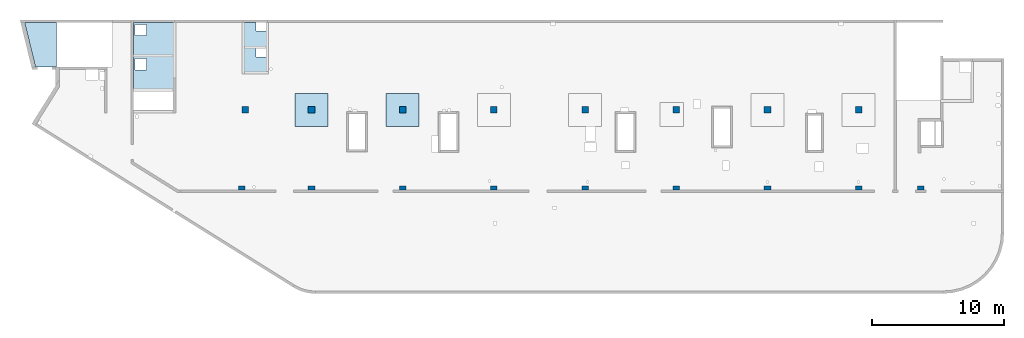
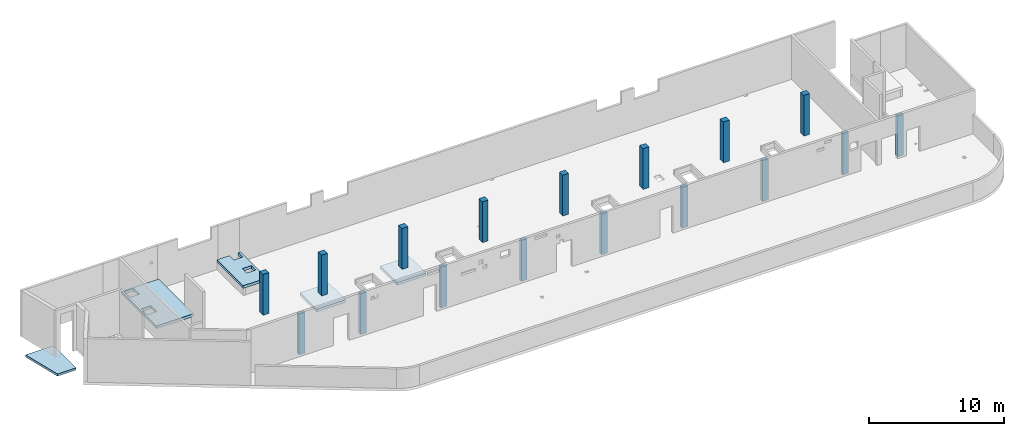
# One storey, part 1 of 6: 17 columns, 5 slabs.
"""IFC4 building model written with IfcOpenShell, lengths in millimetres."""

from ifc_helpers import new_model, entity, si_unit, converted_unit, derived_unit, direction, frame, origin, place, context, subcontext, project, spatial, indexed_curve, outline, extrude, source, transform, mapped, material, type_object, type_shapes, element, save


model = new_model("IFC4")

# Units and contexts
model_context = context("Model", 3, precision=0.01, world=origin(), true_north=direction((6.12303176911189e-17, 1.0)))
plan_context = context("Plan", 3, precision=0.01, world=origin(), true_north=direction((6.12303176911189e-17, 1.0)))
body_context = subcontext(model_context, "Body", "Model", "MODEL_VIEW")
ifc_project = project(units=[si_unit("LENGTHUNIT", "METRE", prefix="MILLI"), si_unit("AREAUNIT", "SQUARE_METRE"), si_unit("VOLUMEUNIT", "CUBIC_METRE"), converted_unit("PLANEANGLEUNIT", "DEGREE", entity("IfcRatioMeasure", 0.0174532925199433), si_unit("PLANEANGLEUNIT", "RADIAN"), dimensions=[0, 0, 0, 0, 0, 0, 0]), si_unit("MASSUNIT", "GRAM", prefix="KILO"), derived_unit("MASSDENSITYUNIT", [(si_unit("MASSUNIT", "GRAM", prefix="KILO"), 1), (si_unit("LENGTHUNIT", "METRE"), -3)]), derived_unit("MOMENTOFINERTIAUNIT", [(si_unit("LENGTHUNIT", "METRE"), 4)]), si_unit("TIMEUNIT", "SECOND"), si_unit("FREQUENCYUNIT", "HERTZ"), si_unit("THERMODYNAMICTEMPERATUREUNIT", "DEGREE_CELSIUS"), derived_unit("THERMALTRANSMITTANCEUNIT", [(si_unit("MASSUNIT", "GRAM", prefix="KILO"), 1), (si_unit("THERMODYNAMICTEMPERATUREUNIT", "KELVIN"), -1), (si_unit("TIMEUNIT", "SECOND"), -3)]), derived_unit("VOLUMETRICFLOWRATEUNIT", [(si_unit("LENGTHUNIT", "METRE"), 3), (si_unit("TIMEUNIT", "SECOND"), -1)]), derived_unit("MASSFLOWRATEUNIT", [(si_unit("MASSUNIT", "GRAM", prefix="KILO"), 1), (si_unit("TIMEUNIT", "SECOND"), -1)]), derived_unit("ROTATIONALFREQUENCYUNIT", [(si_unit("TIMEUNIT", "SECOND"), -1)]), si_unit("ELECTRICCURRENTUNIT", "AMPERE"), si_unit("ELECTRICVOLTAGEUNIT", "VOLT"), si_unit("POWERUNIT", "WATT"), si_unit("FORCEUNIT", "NEWTON", prefix="KILO"), si_unit("ILLUMINANCEUNIT", "LUX"), si_unit("LUMINOUSFLUXUNIT", "LUMEN"), si_unit("LUMINOUSINTENSITYUNIT", "CANDELA"), derived_unit("USERDEFINED", [(si_unit("MASSUNIT", "GRAM", prefix="KILO"), -1), (si_unit("LENGTHUNIT", "METRE"), -2), (si_unit("TIMEUNIT", "SECOND"), 3), (si_unit("LUMINOUSFLUXUNIT", "LUMEN"), 1)]), derived_unit("LINEARVELOCITYUNIT", [(si_unit("LENGTHUNIT", "METRE"), 1), (si_unit("TIMEUNIT", "SECOND"), -1)]), si_unit("PRESSUREUNIT", "PASCAL"), derived_unit("USERDEFINED", [(si_unit("LENGTHUNIT", "METRE"), -2), (si_unit("MASSUNIT", "GRAM", prefix="KILO"), 1), (si_unit("TIMEUNIT", "SECOND"), -2)]), derived_unit("LINEARFORCEUNIT", [(si_unit("MASSUNIT", "GRAM", prefix="KILO"), 1), (si_unit("LENGTHUNIT", "METRE"), 1), (si_unit("TIMEUNIT", "SECOND"), -2), (si_unit("LENGTHUNIT", "METRE"), -1)]), derived_unit("PLANARFORCEUNIT", [(si_unit("MASSUNIT", "GRAM", prefix="KILO"), 1), (si_unit("LENGTHUNIT", "METRE"), 1), (si_unit("TIMEUNIT", "SECOND"), -2), (si_unit("LENGTHUNIT", "METRE"), -2)])], contexts=[model_context, plan_context])

# Site, building, storey
site_placement = place(None, origin())
site = spatial("IfcSite", under=ifc_project, at=site_placement, CompositionType="ELEMENT")
building_placement = place(site_placement, origin())
building = spatial("IfcBuilding", under=site, at=building_placement, CompositionType="ELEMENT")
storey_placement = place(building_placement, frame((0.0, 0.0, 28200.0)))
storey = spatial("IfcBuildingStorey", under=building, at=storey_placement, CompositionType="ELEMENT", Elevation=28200.0)

# Columns
ifc_material = material()
column_type_1 = type_object("IfcColumnType", PredefinedType="COLUMN", material=ifc_material)
shared_shape_1 = source(origin(), body_context, "Body", "SweptSolid", [
    extrude(outline(indexed_curve([(-149.999999999996, -249.999999999999), (149.999999999995, -249.999999999999), (149.999999999997, 249.999999999999), (-149.999999999997, 249.999999999999), (-149.999999999996, -249.999999999999)], self_intersect=False)), frame((15899.9995239258, 7799.99922635584, 28050.0), z_axis=(0.0, 0.0, 1.0), x_axis=(0.0, -1.0, 0.0)), (0.0, 0.0, 1.0), 3700.0),
])
type_shapes(column_type_1, [shared_shape_1])
column_1_placement = place(storey_placement, frame((0.0, 0.0, -28200.0)))
element("IfcColumn", 1, at=column_1_placement, inside=storey, type_object=column_type_1, PredefinedType="COLUMN", context=body_context, shape_type="MappedRepresentation", body=[
    mapped(shared_shape_1, transform((0.0, 0.0, 0.0), scale=1.0)),
])
column_type_2 = type_object("IfcColumnType", PredefinedType="COLUMN", material=ifc_material)
shared_shape_2 = source(origin(), body_context, "Body", "SweptSolid", [
    extrude(outline(indexed_curve([(-149.999999999996, -249.999999999999), (149.999999999995, -249.999999999999), (149.999999999996, 249.999999999999), (-149.999999999997, 249.999999999999), (-149.999999999996, -249.999999999999)], self_intersect=False)), frame((21170.0002685547, 7799.99922635582, 28050.0), z_axis=(0.0, 0.0, 1.0), x_axis=(0.0, -1.0, 0.0)), (0.0, 0.0, 1.0), 3700.0),
])
type_shapes(column_type_2, [shared_shape_2])
column_2_placement = place(storey_placement, frame((0.0, 0.0, -28200.0)))
element("IfcColumn", 2, at=column_2_placement, inside=storey, type_object=column_type_2, PredefinedType="COLUMN", context=body_context, shape_type="MappedRepresentation", body=[
    mapped(shared_shape_2, transform((0.0, 0.0, 0.0), scale=1.0)),
])
column_type_3 = type_object("IfcColumnType", PredefinedType="COLUMN", material=ifc_material)
shared_shape_3 = source(origin(), body_context, "Body", "SweptSolid", [
    extrude(outline(indexed_curve([(-149.999999999996, -249.999999999999), (149.999999999995, -249.999999999999), (149.999999999996, 249.999999999999), (-149.999999999996, 249.999999999999), (-149.999999999996, -249.999999999999)], self_intersect=False)), frame((28070.0002685547, 7799.9992263558, 28050.0), z_axis=(0.0, 0.0, 1.0), x_axis=(0.0, -1.0, 0.0)), (0.0, 0.0, 1.0), 3700.0),
])
type_shapes(column_type_3, [shared_shape_3])
column_3_placement = place(storey_placement, frame((0.0, 0.0, -28200.0)))
element("IfcColumn", 3, at=column_3_placement, inside=storey, type_object=column_type_3, PredefinedType="COLUMN", context=body_context, shape_type="MappedRepresentation", body=[
    mapped(shared_shape_3, transform((0.0, 0.0, 0.0), scale=1.0)),
])
column_type_4 = type_object("IfcColumnType", PredefinedType="COLUMN", material=ifc_material)
shared_shape_4 = source(origin(), body_context, "Body", "SweptSolid", [
    extrude(outline(indexed_curve([(-149.999999999994, -249.999999999999), (149.999999999995, -249.999999999999), (149.999999999996, 249.999999999995), (-149.999999999995, 249.999999999999), (-149.999999999994, -249.999999999999)], self_intersect=False)), frame((34970.0002685547, 7799.99922635578, 28050.0), z_axis=(0.0, 0.0, 1.0), x_axis=(0.0, -1.0, 0.0)), (0.0, 0.0, 1.0), 3700.0),
])
type_shapes(column_type_4, [shared_shape_4])
column_4_placement = place(storey_placement, frame((0.0, 0.0, -28200.0)))
element("IfcColumn", 4, at=column_4_placement, inside=storey, type_object=column_type_4, PredefinedType="COLUMN", context=body_context, shape_type="MappedRepresentation", body=[
    mapped(shared_shape_4, transform((0.0, 0.0, 0.0), scale=1.0)),
])
column_type_5 = type_object("IfcColumnType", PredefinedType="COLUMN", material=ifc_material)
shared_shape_5 = source(origin(), body_context, "Body", "SweptSolid", [
    extrude(outline(indexed_curve([(-149.999999999994, -250.000000000004), (149.999999999995, -250.000000000004), (149.999999999996, 250.000000000004), (-149.999999999994, 250.000000000004), (-149.999999999994, -250.000000000004)], self_intersect=False)), frame((41870.0002685547, 7799.99922635576, 28050.0), z_axis=(0.0, 0.0, 1.0), x_axis=(0.0, -1.0, 0.0)), (0.0, 0.0, 1.0), 3700.0),
])
type_shapes(column_type_5, [shared_shape_5])
column_5_placement = place(storey_placement, frame((0.0, 0.0, -28200.0)))
element("IfcColumn", 5, at=column_5_placement, inside=storey, type_object=column_type_5, PredefinedType="COLUMN", context=body_context, shape_type="MappedRepresentation", body=[
    mapped(shared_shape_5, transform((0.0, 0.0, 0.0), scale=1.0)),
])
column_type_6 = type_object("IfcColumnType", PredefinedType="COLUMN", material=ifc_material)
shared_shape_6 = source(origin(), body_context, "Body", "SweptSolid", [
    extrude(outline(indexed_curve([(-149.999999999994, -250.000000000004), (149.999999999993, -250.000000000004), (149.999999999994, 250.000000000004), (-149.999999999995, 250.000000000004), (-149.999999999994, -250.000000000004)], self_intersect=False)), frame((48770.0002685547, 7799.99922635573, 28050.0), z_axis=(0.0, 0.0, 1.0), x_axis=(0.0, -1.0, 0.0)), (0.0, 0.0, 1.0), 3700.0),
])
type_shapes(column_type_6, [shared_shape_6])
column_6_placement = place(storey_placement, frame((0.0, 0.0, -28200.0)))
element("IfcColumn", 6, at=column_6_placement, inside=storey, type_object=column_type_6, PredefinedType="COLUMN", context=body_context, shape_type="MappedRepresentation", body=[
    mapped(shared_shape_6, transform((0.0, 0.0, 0.0), scale=1.0)),
])
column_type_7 = type_object("IfcColumnType", PredefinedType="COLUMN", material=ifc_material)
shared_shape_7 = source(origin(), body_context, "Body", "SweptSolid", [
    extrude(outline(indexed_curve([(-149.999999999994, -250.000000000004), (149.999999999993, -250.000000000004), (149.999999999994, 250.000000000004), (-149.999999999994, 250.000000000004), (-149.999999999994, -250.000000000004)], self_intersect=False)), frame((55670.0002685547, 7799.99922635571, 28050.0), z_axis=(0.0, 0.0, 1.0), x_axis=(0.0, -1.0, 0.0)), (0.0, 0.0, 1.0), 3700.0),
])
type_shapes(column_type_7, [shared_shape_7])
column_7_placement = place(storey_placement, frame((0.0, 0.0, -28200.0)))
element("IfcColumn", 7, at=column_7_placement, inside=storey, type_object=column_type_7, PredefinedType="COLUMN", context=body_context, shape_type="MappedRepresentation", body=[
    mapped(shared_shape_7, transform((0.0, 0.0, 0.0), scale=1.0)),
])
column_type_8 = type_object("IfcColumnType", PredefinedType="COLUMN", material=ifc_material)
shared_shape_8 = source(origin(), body_context, "Body", "SweptSolid", [
    extrude(outline(indexed_curve([(-149.999999999992, -250.000000000004), (149.999999999993, -250.000000000004), (149.999999999995, 250.000000000004), (-149.999999999993, 250.000000000004), (-149.999999999992, -250.000000000004)], self_intersect=False)), frame((62570.0002685547, 7799.99922635569, 28050.0), z_axis=(0.0, 0.0, 1.0), x_axis=(0.0, -1.0, 0.0)), (0.0, 0.0, 1.0), 3700.0),
])
type_shapes(column_type_8, [shared_shape_8])
column_8_placement = place(storey_placement, frame((0.0, 0.0, -28200.0)))
element("IfcColumn", 8, at=column_8_placement, inside=storey, type_object=column_type_8, PredefinedType="COLUMN", context=body_context, shape_type="MappedRepresentation", body=[
    mapped(shared_shape_8, transform((0.0, 0.0, 0.0), scale=1.0)),
])
column_type_9 = type_object("IfcColumnType", PredefinedType="COLUMN", material=ifc_material)
shared_shape_9 = source(origin(), body_context, "Body", "SweptSolid", [
    extrude(outline(indexed_curve([(-149.999999999992, -250.000000000004), (149.999999999993, -250.000000000004), (149.999999999994, 250.000000000004), (-149.999999999993, 250.000000000004), (-149.999999999992, -250.000000000004)], self_intersect=False)), frame((67270.0002685547, 7799.99922635567, 28050.0), z_axis=(0.0, 0.0, 1.0), x_axis=(0.0, -1.0, 0.0)), (0.0, 0.0, 1.0), 3700.0),
])
type_shapes(column_type_9, [shared_shape_9])
column_9_placement = place(storey_placement, frame((0.0, 0.0, -28200.0)))
element("IfcColumn", 9, at=column_9_placement, inside=storey, type_object=column_type_9, PredefinedType="COLUMN", context=body_context, shape_type="MappedRepresentation", body=[
    mapped(shared_shape_9, transform((0.0, 0.0, 0.0), scale=1.0)),
])
column_type_10 = type_object("IfcColumnType", PredefinedType="COLUMN", material=ifc_material)
shared_shape_10 = source(origin(), body_context, "Body", "SweptSolid", [
    extrude(outline(indexed_curve([(-249.999999999999, -250.000000000004), (249.999999999999, -250.000000000004), (249.999999999999, 249.999999999995), (-249.999999999999, 250.000000000004), (-249.999999999999, -250.000000000004)], self_intersect=False)), frame((62570.0002685547, 13699.9992263555, 28050.0), z_axis=(0.0, 0.0, 1.0), x_axis=(0.0, -1.0, 0.0)), (0.0, 0.0, 1.0), 3700.0),
])
type_shapes(column_type_10, [shared_shape_10])
column_10_placement = place(storey_placement, frame((0.0, 0.0, -28200.0)))
element("IfcColumn", 10, at=column_10_placement, inside=storey, type_object=column_type_10, PredefinedType="COLUMN", context=body_context, shape_type="MappedRepresentation", body=[
    mapped(shared_shape_10, transform((0.0, 0.0, 0.0), scale=1.0)),
])
column_type_11 = type_object("IfcColumnType", PredefinedType="COLUMN", material=ifc_material)
shared_shape_11 = source(origin(), body_context, "Body", "SweptSolid", [
    extrude(outline(indexed_curve([(-249.999999999999, -250.000000000004), (249.999999999999, -250.000000000004), (249.999999999999, 249.999999999995), (-249.999999999999, 250.000000000004), (-249.999999999999, -250.000000000004)], self_intersect=False)), frame((55670.0002685547, 13699.9992263555, 28050.0), z_axis=(0.0, 0.0, 1.0), x_axis=(0.0, -1.0, 0.0)), (0.0, 0.0, 1.0), 3700.0),
])
type_shapes(column_type_11, [shared_shape_11])
column_11_placement = place(storey_placement, frame((0.0, 0.0, -28200.0)))
element("IfcColumn", 11, at=column_11_placement, inside=storey, type_object=column_type_11, PredefinedType="COLUMN", context=body_context, shape_type="MappedRepresentation", body=[
    mapped(shared_shape_11, transform((0.0, 0.0, 0.0), scale=1.0)),
])
column_type_12 = type_object("IfcColumnType", PredefinedType="COLUMN", material=ifc_material)
shared_shape_12 = source(origin(), body_context, "Body", "SweptSolid", [
    extrude(outline(indexed_curve([(-249.999999999999, -250.000000000004), (249.999999999999, -250.000000000004), (249.999999999999, 249.999999999995), (-249.999999999999, 250.000000000004), (-249.999999999999, -250.000000000004)], self_intersect=False)), frame((48770.0002685547, 13699.9992263556, 28050.0), z_axis=(0.0, 0.0, 1.0), x_axis=(0.0, -1.0, 0.0)), (0.0, 0.0, 1.0), 3700.0),
])
type_shapes(column_type_12, [shared_shape_12])
column_12_placement = place(storey_placement, frame((0.0, 0.0, -28200.0)))
element("IfcColumn", 12, at=column_12_placement, inside=storey, type_object=column_type_12, PredefinedType="COLUMN", context=body_context, shape_type="MappedRepresentation", body=[
    mapped(shared_shape_12, transform((0.0, 0.0, 0.0), scale=1.0)),
])
column_type_13 = type_object("IfcColumnType", PredefinedType="COLUMN", material=ifc_material)
shared_shape_13 = source(origin(), body_context, "Body", "SweptSolid", [
    extrude(outline(indexed_curve([(-249.999999999999, -250.000000000004), (249.999999999999, -250.000000000004), (249.999999999999, 249.999999999995), (-249.999999999999, 250.000000000004), (-249.999999999999, -250.000000000004)], self_intersect=False)), frame((41870.0002685547, 13699.9992263556, 28050.0), z_axis=(0.0, 0.0, 1.0), x_axis=(0.0, -1.0, 0.0)), (0.0, 0.0, 1.0), 3700.0),
])
type_shapes(column_type_13, [shared_shape_13])
column_13_placement = place(storey_placement, frame((0.0, 0.0, -28200.0)))
element("IfcColumn", 13, at=column_13_placement, inside=storey, type_object=column_type_13, PredefinedType="COLUMN", context=body_context, shape_type="MappedRepresentation", body=[
    mapped(shared_shape_13, transform((0.0, 0.0, 0.0), scale=1.0)),
])
column_type_14 = type_object("IfcColumnType", PredefinedType="COLUMN", material=ifc_material)
shared_shape_14 = source(origin(), body_context, "Body", "SweptSolid", [
    extrude(outline(indexed_curve([(-249.999999999999, -249.999999999999), (249.999999999999, -249.999999999999), (249.999999999999, 249.999999999999), (-249.999999999999, 249.999999999999), (-249.999999999999, -249.999999999999)], self_intersect=False)), frame((34970.0002685547, 13699.9992263556, 28050.0), z_axis=(0.0, 0.0, 1.0), x_axis=(0.0, -1.0, 0.0)), (0.0, 0.0, 1.0), 3700.0),
])
type_shapes(column_type_14, [shared_shape_14])
column_14_placement = place(storey_placement, frame((0.0, 0.0, -28200.0)))
element("IfcColumn", 14, at=column_14_placement, inside=storey, type_object=column_type_14, PredefinedType="COLUMN", context=body_context, shape_type="MappedRepresentation", body=[
    mapped(shared_shape_14, transform((0.0, 0.0, 0.0), scale=1.0)),
])
column_type_15 = type_object("IfcColumnType", PredefinedType="COLUMN", material=ifc_material)
shared_shape_15 = source(origin(), body_context, "Body", "SweptSolid", [
    extrude(outline(indexed_curve([(-249.999999999999, -249.999999999999), (249.999999999999, -249.999999999999), (249.999999999999, 249.999999999999), (-249.999999999999, 249.999999999999), (-249.999999999999, -249.999999999999)], self_intersect=False)), frame((28070.0002685547, 13699.9992263556, 28050.0), z_axis=(0.0, 0.0, 1.0), x_axis=(0.0, -1.0, 0.0)), (0.0, 0.0, 1.0), 3700.0),
])
type_shapes(column_type_15, [shared_shape_15])
column_15_placement = place(storey_placement, frame((0.0, 0.0, -28200.0)))
element("IfcColumn", 15, at=column_15_placement, inside=storey, type_object=column_type_15, PredefinedType="COLUMN", context=body_context, shape_type="MappedRepresentation", body=[
    mapped(shared_shape_15, transform((0.0, 0.0, 0.0), scale=1.0)),
])
column_type_16 = type_object("IfcColumnType", PredefinedType="COLUMN", material=ifc_material)
shared_shape_16 = source(origin(), body_context, "Body", "SweptSolid", [
    extrude(outline(indexed_curve([(-249.999999999999, -249.999999999999), (249.999999999999, -249.999999999999), (249.999999999999, 249.999999999999), (-249.999999999999, 249.999999999999), (-249.999999999999, -249.999999999999)], self_intersect=False)), frame((21170.0002685547, 13699.9992263556, 28050.0), z_axis=(0.0, 0.0, 1.0), x_axis=(0.0, -1.0, 0.0)), (0.0, 0.0, 1.0), 3700.0),
])
type_shapes(column_type_16, [shared_shape_16])
column_16_placement = place(storey_placement, frame((0.0, 0.0, -28200.0)))
element("IfcColumn", 16, at=column_16_placement, inside=storey, type_object=column_type_16, PredefinedType="COLUMN", context=body_context, shape_type="MappedRepresentation", body=[
    mapped(shared_shape_16, transform((0.0, 0.0, 0.0), scale=1.0)),
])
column_type_17 = type_object("IfcColumnType", PredefinedType="COLUMN", material=ifc_material)
shared_shape_17 = source(origin(), body_context, "Body", "SweptSolid", [
    extrude(outline(indexed_curve([(-249.999999999999, -249.999999999999), (249.999999999999, -249.999999999999), (249.999999999999, 249.999999999999), (-249.999999999999, 249.999999999999), (-249.999999999999, -249.999999999999)], self_intersect=False)), frame((16150.0002685547, 13699.9992263557, 28050.0), z_axis=(0.0, 0.0, 1.0), x_axis=(0.0, -1.0, 0.0)), (0.0, 0.0, 1.0), 3700.0),
])
type_shapes(column_type_17, [shared_shape_17])
column_17_placement = place(storey_placement, frame((0.0, 0.0, -28200.0)))
element("IfcColumn", 17, at=column_17_placement, inside=storey, type_object=column_type_17, PredefinedType="COLUMN", context=body_context, shape_type="MappedRepresentation", body=[
    mapped(shared_shape_17, transform((0.0, 0.0, 0.0), scale=1.0)),
])

# Slabs
slab_type_1 = type_object("IfcSlabType", PredefinedType="FLOOR", material=ifc_material)
slab_1_placement = place(storey_placement, origin())
element("IfcSlab", 18, at=slab_1_placement, inside=storey, type_object=slab_type_1, material=ifc_material, PredefinedType="FLOOR", context=body_context, shape_type="SweptSolid", body=[
    extrude(outline(indexed_curve([(-1640.0, -2980.0000639367), (-1439.99999999999, -2980.0000639367), (1559.99999999999, -2980.0000639367), (1559.99999999999, -580.000063936673), (1559.99999999999, -380.000063936673), (1559.99999999999, 2019.99993606334), (1559.99999999999, 2219.99993606334), (-1439.99999999999, 2219.99993606334), (-1640.0, 2219.99993606334), (-1640.0, 1220.00057543014), (-1640.0, -2980.0000639367)], self_intersect=False), holes=[indexed_curve([(585.0, -255.000063936664), (585.0, 594.999936063335), (1435.0, 594.999936063335), (1435.0, -255.000063936664), (585.0, -255.000063936664)], self_intersect=False), indexed_curve([(584.999999999996, -2855.00006393667), (584.999999999996, -2005.00006393667), (1435.0, -2005.00006393667), (1435.0, -2855.00006393667), (584.999999999996, -2855.00006393667)], self_intersect=False)]), frame((9260.0002685547, 17319.999801786, 500.0), z_axis=(0.0, 0.0, 1.0), x_axis=(-1.0, 0.0, 0.0)), (0.0, 0.0, 1.0), 249.999999999999),
])
slab_type_2 = type_object("IfcSlabType", PredefinedType="FLOOR", material=ifc_material)
slab_2_placement = place(storey_placement, origin())
element("IfcSlab", 19, at=slab_2_placement, inside=storey, type_object=slab_type_2, material=ifc_material, PredefinedType="FLOOR", context=body_context, shape_type="SweptSolid", body=[
    extrude(outline(indexed_curve([(-913.636363636355, -1518.18216692726), (-713.636363636364, -1518.18216692726), (-713.636363636364, -868.181527560958), (61.3636363636352, -868.181527560958), (61.3636363636352, -1518.18216692726), (911.363636363622, -1518.18216692726), (1111.36363636363, -1518.18216692726), (1111.36363636363, 2381.81847243956), (911.363636363628, 2381.81847243956), (-913.636363636355, 2381.81847243956), (-913.636363636355, 2181.81847243956), (-913.636363636355, -1518.18216692726)], self_intersect=False), holes=[indexed_curve([(-713.636363636362, 431.817833072721), (-713.636363636362, 1081.81783307272), (61.3636363636374, 1081.81783307272), (61.3636363636374, 431.817833072721), (-713.636363636362, 431.817833072721)], self_intersect=False)]), frame((17011.3639049183, 18781.8176987954, 500.0), z_axis=(0.0, 0.0, 1.0), x_axis=(-1.0, 0.0, 0.0)), (0.0, 0.0, 1.0), 249.999999999999),
])
slab_type_3 = type_object("IfcSlabType", PredefinedType="FLOOR", material=ifc_material)
slab_3_placement = place(storey_placement, origin())
element("IfcSlab", 20, at=slab_3_placement, inside=storey, type_object=slab_type_3, material=ifc_material, PredefinedType="FLOOR", context=body_context, shape_type="SweptSolid", body=[
    extrude(outline(indexed_curve([(-998.540084126058, -1670.00000000026), (591.459915873942, -1670.00000000026), (1405.62025237818, 1670.00000000027), (-998.540084126064, 1670.00000000026), (-998.540084126058, -1670.00000000026)], self_intersect=False)), frame((870.777951917378, 18629.9992263562, -2130.0), z_axis=(0.0, 0.0, -1.0), x_axis=(-1.0, 0.0, 0.0)), (0.0, 0.0, 1.0), 199.999999999998),
])
slab_type_4 = type_object("IfcSlabType", PredefinedType="FLOOR", material=ifc_material)
slab_4_placement = place(storey_placement, origin())
element("IfcSlab", 21, at=slab_4_placement, inside=storey, type_object=slab_type_4, material=ifc_material, PredefinedType="FLOOR", context=body_context, shape_type="SweptSolid", body=[
    extrude(outline(indexed_curve([(-1250.0, -1250.0), (1250.0, -1250.0), (1250.0, 1250.0), (-1250.0, 1250.0), (-1250.0, -1250.0)], self_intersect=False)), frame((21170.0002685546, 13699.9992263563, -400.0), z_axis=(0.0, 0.0, -1.0), x_axis=(0.0, 1.0, 0.0)), (0.0, 0.0, 1.0), 249.999999999999),
])
slab_type_5 = type_object("IfcSlabType", PredefinedType="FLOOR", material=ifc_material)
slab_5_placement = place(storey_placement, origin())
element("IfcSlab", 22, at=slab_5_placement, inside=storey, type_object=slab_type_5, material=ifc_material, PredefinedType="FLOOR", context=body_context, shape_type="SweptSolid", body=[
    extrude(outline(indexed_curve([(-1250.0, -1250.0), (1250.0, -1250.0), (1250.0, 1250.0), (-1250.0, 1250.0), (-1250.0, -1250.0)], self_intersect=False)), frame((28070.0002685546, 13699.9992263563, -400.0), z_axis=(0.0, 0.0, -1.0), x_axis=(0.0, 1.0, 0.0)), (0.0, 0.0, 1.0), 249.999999999999),
])

save(model, "model.ifc")
